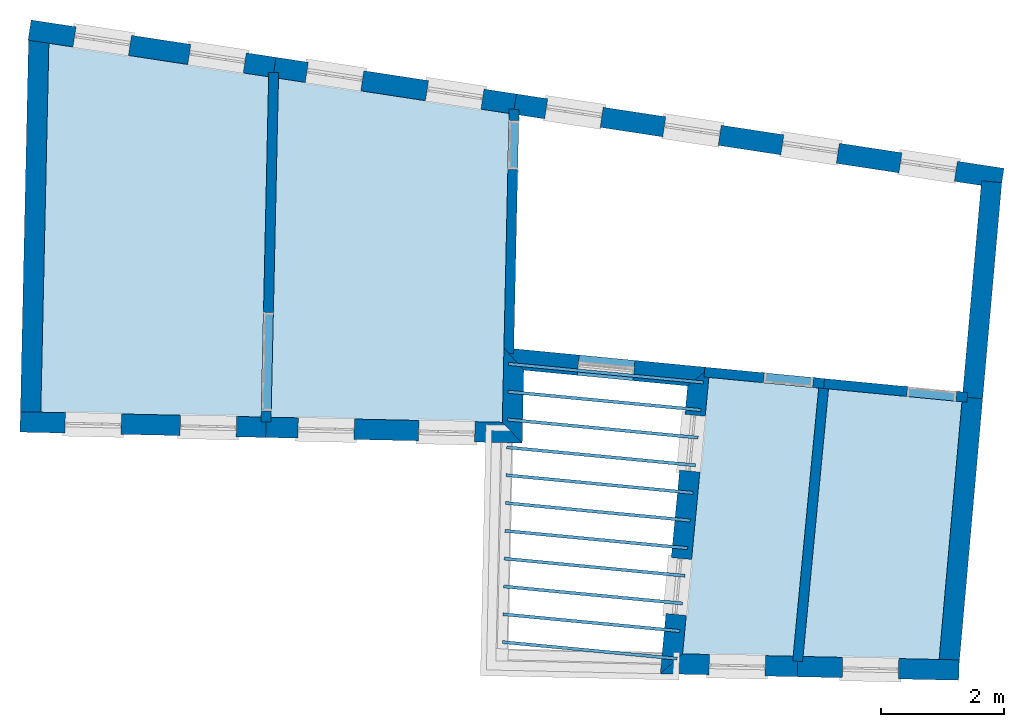
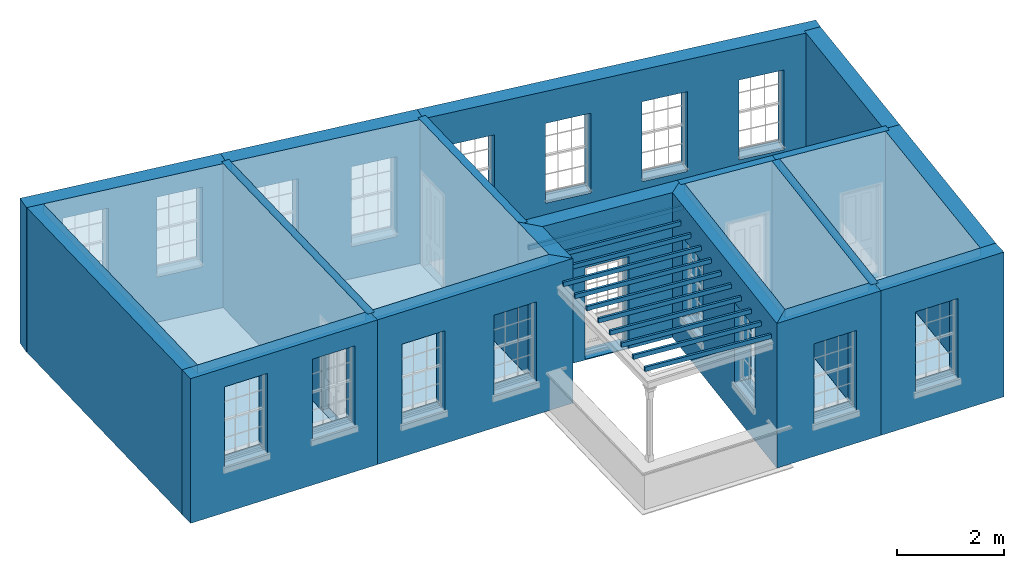
# One storey, part 1 of 12: 19 slabs, 18 walls, 21 openings.
"""IFC2X3 building model written with IfcOpenShell, lengths in metres."""

from ifc_helpers import new_model, si_unit, frame, origin, place, context, subcontext, project, spatial, polyline, outline, extrude, material, layer, layer_set, layer_usage, element, save


model = new_model("IFC2X3")

# Units and contexts
model_context = context("Model", 3, world=origin())
body_context = subcontext(model_context, "Body", "Model", "MODEL_VIEW")
ifc_project = project(units=[si_unit("PLANEANGLEUNIT", "RADIAN"), si_unit("MASSUNIT", "GRAM", prefix="KILO"), si_unit("FORCEUNIT", "NEWTON", prefix="KILO"), si_unit("LENGTHUNIT", "METRE")], contexts=[model_context])

# Site, building, storey
site_placement = place(None, origin())
site = spatial("IfcSite", under=ifc_project, at=site_placement, CompositionType="ELEMENT")
building_placement = place(None, origin())
building = spatial("IfcBuilding", under=site, at=building_placement, Name="Building plot-18", CompositionType="ELEMENT")
storey_placement = place(None, frame((0.0, 0.0, 6.6)))
storey = spatial("IfcBuildingStorey", under=building, at=storey_placement, Name="Floor 1", CompositionType="ELEMENT", Elevation=6.6)

# Slabs
slab_1_placement = place(storey_placement, frame((0.0, 0.0, 3.1)))
element("IfcSlab", 1, at=slab_1_placement, inside=storey, Name="Slab", ObjectType="Slab", PredefinedType="FLOOR", context=body_context, shape_type="SweptSolid", body=[
    extrude(outline(polyline([(90.0665092699253, 26.2497874759224), (86.5022934800522, 26.793269433689), (86.3714411265754, 20.8107101060855), (89.9458341375318, 20.7325298972281), (90.0665092699253, 26.2497874759224)])), origin(), (0.0, 0.0, 1.0), 0.2),
])
slab_2_placement = place(storey_placement, frame((0.0, 0.0, 2.8)))
element("IfcSlab", 2, at=slab_2_placement, inside=storey, Name="Slab", ObjectType="Slab", PredefinedType="FLOOR", context=body_context, shape_type="SweptSolid", body=[
    extrude(outline(polyline([(96.6890640935905, 16.7886954747635), (96.6938006517783, 16.8384706193291), (93.8601903908581, 17.1081144345203), (93.8554538326703, 17.0583392899546), (96.6890640935905, 16.7886954747635)])), origin(), (0.0, 0.0, 1.0), 0.1),
])
slab_3_placement = place(storey_placement, frame((0.0, 0.0, 2.8)))
element("IfcSlab", 3, at=slab_3_placement, inside=storey, Name="Slab", ObjectType="Slab", PredefinedType="FLOOR", context=body_context, shape_type="SweptSolid", body=[
    extrude(outline(polyline([(96.7316931172806, 17.2366717758545), (96.7364296754684, 17.2864469204202), (93.8700568548032, 17.5592083914608), (93.8653202966154, 17.5094332468951), (96.7316931172806, 17.2366717758545)])), origin(), (0.0, 0.0, 1.0), 0.1),
])
slab_4_placement = place(storey_placement, frame((0.0, 0.0, 2.8)))
element("IfcSlab", 4, at=slab_4_placement, inside=storey, Name="Slab", ObjectType="Slab", PredefinedType="FLOOR", context=body_context, shape_type="SweptSolid", body=[
    extrude(outline(polyline([(96.7743221409708, 17.6846480769456), (96.7790586991586, 17.7344232215112), (93.8799233187482, 18.0103023484013), (93.8751867605604, 17.9605272038357), (96.7743221409708, 17.6846480769456)])), origin(), (0.0, 0.0, 1.0), 0.1),
])
slab_5_placement = place(storey_placement, frame((0.0, 0.0, 2.8)))
element("IfcSlab", 5, at=slab_5_placement, inside=storey, Name="Slab", ObjectType="Slab", PredefinedType="FLOOR", context=body_context, shape_type="SweptSolid", body=[
    extrude(outline(polyline([(96.8169511646609, 18.1326243780366), (96.8216877228487, 18.1823995226023), (93.8897897826932, 18.4613963053419), (93.8850532245054, 18.4116211607762), (96.8169511646609, 18.1326243780366)])), origin(), (0.0, 0.0, 1.0), 0.1),
])
slab_6_placement = place(storey_placement, frame((0.0, 0.0, 2.8)))
element("IfcSlab", 6, at=slab_6_placement, inside=storey, Name="Slab", ObjectType="Slab", PredefinedType="FLOOR", context=body_context, shape_type="SweptSolid", body=[
    extrude(outline(polyline([(96.8595801883511, 18.5806006791277), (96.8643167465389, 18.6303758236934), (93.8996562466383, 18.9124902622824), (93.8949196884505, 18.8627151177167), (96.8595801883511, 18.5806006791277)])), origin(), (0.0, 0.0, 1.0), 0.1),
])
slab_7_placement = place(storey_placement, frame((0.0, 0.0, 2.8)))
element("IfcSlab", 7, at=slab_7_placement, inside=storey, Name="Slab", ObjectType="Slab", PredefinedType="FLOOR", context=body_context, shape_type="SweptSolid", body=[
    extrude(outline(polyline([(96.9022092120412, 19.0285769802188), (96.906945770229, 19.0783521247844), (93.9095227105833, 19.3635842192229), (93.9047861523955, 19.3138090746573), (96.9022092120412, 19.0285769802188)])), origin(), (0.0, 0.0, 1.0), 0.1),
])
slab_8_placement = place(storey_placement, frame((0.0, 0.0, 2.8)))
element("IfcSlab", 8, at=slab_8_placement, inside=storey, Name="Slab", ObjectType="Slab", PredefinedType="FLOOR", context=body_context, shape_type="SweptSolid", body=[
    extrude(outline(polyline([(96.9448382357314, 19.4765532813098), (96.9495747939192, 19.5263284258755), (93.9193891745284, 19.8146781761635), (93.9146526163406, 19.7649030315978), (96.9448382357314, 19.4765532813098)])), origin(), (0.0, 0.0, 1.0), 0.1),
])
slab_9_placement = place(storey_placement, frame((0.0, 0.0, 2.8)))
element("IfcSlab", 9, at=slab_9_placement, inside=storey, Name="Slab", ObjectType="Slab", PredefinedType="FLOOR", context=body_context, shape_type="SweptSolid", body=[
    extrude(outline(polyline([(96.9874672594215, 19.9245295824009), (96.9922038176093, 19.9743047269665), (93.9292556384734, 20.265772133104), (93.9245190802856, 20.2159969885383), (96.9874672594215, 19.9245295824009)])), origin(), (0.0, 0.0, 1.0), 0.1),
])
slab_10_placement = place(storey_placement, frame((0.0, 0.0, 2.8)))
element("IfcSlab", 10, at=slab_10_placement, inside=storey, Name="Slab", ObjectType="Slab", PredefinedType="FLOOR", context=body_context, shape_type="SweptSolid", body=[
    extrude(outline(polyline([(97.0300962831116, 20.3725058834919), (97.0348328412994, 20.4222810280576), (93.9391221024184, 20.7168660900445), (93.9343855442306, 20.6670909454789), (97.0300962831116, 20.3725058834919)])), origin(), (0.0, 0.0, 1.0), 0.1),
])
slab_11_placement = place(storey_placement, frame((0.0, 0.0, 2.8)))
element("IfcSlab", 11, at=slab_11_placement, inside=storey, Name="Slab", ObjectType="Slab", PredefinedType="FLOOR", context=body_context, shape_type="SweptSolid", body=[
    extrude(outline(polyline([(97.0727253068018, 20.820482184583), (97.0774618649896, 20.8702573291487), (93.9489885663635, 21.1679600469851), (93.9442520081757, 21.1181849024194), (97.0727253068018, 20.820482184583)])), origin(), (0.0, 0.0, 1.0), 0.1),
])
slab_12_placement = place(storey_placement, frame((0.0, 0.0, 2.8)))
element("IfcSlab", 12, at=slab_12_placement, inside=storey, Name="Slab", ObjectType="Slab", PredefinedType="FLOOR", context=body_context, shape_type="SweptSolid", body=[
    extrude(outline(polyline([(97.1153543304919, 21.268458485674), (97.1200908886797, 21.3182336302397), (93.9588550303085, 21.6190540039256), (93.9541184721207, 21.5692788593599), (97.1153543304919, 21.268458485674)])), origin(), (0.0, 0.0, 1.0), 0.1),
])
slab_13_placement = place(storey_placement, frame((0.0, 0.0, 3.1)))
element("IfcSlab", 13, at=slab_13_placement, inside=storey, Name="Slab", ObjectType="Slab", PredefinedType="FLOOR", context=body_context, shape_type="SweptSolid", body=[
    extrude(outline(polyline([(93.9652937343678, 25.6552895166051), (90.2260155594004, 26.2254654944291), (90.1057958794453, 20.7290311654569), (93.8557511466322, 20.6470110056427), (93.9652937343678, 25.6552895166051)])), origin(), (0.0, 0.0, 1.0), 0.2),
])
slab_14_placement = place(storey_placement, frame((0.0, 0.0, 3.1)))
element("IfcSlab", 14, at=slab_14_placement, inside=storey, Name="Slab", ObjectType="Slab", PredefinedType="FLOOR", context=body_context, shape_type="SweptSolid", body=[
    extrude(outline(polyline([(96.7792255874086, 16.8916819408247), (98.5722410978442, 16.8524645613532), (98.9862368117979, 21.2030279228927), (97.2057969153529, 21.3743988576596), (96.7792255874086, 16.8916819408247)])), origin(), (0.0, 0.0, 1.0), 0.2),
])
slab_15_placement = place(storey_placement, frame((0.0, 0.0, 3.1)))
element("IfcSlab", 15, at=slab_15_placement, inside=storey, Name="Slab", ObjectType="Slab", PredefinedType="FLOOR", context=body_context, shape_type="SweptSolid", body=[
    extrude(outline(polyline([(98.7326300603119, 16.8489564852837), (100.939309623709, 16.8006913200882), (101.309526101752, 20.9794066379798), (99.1455008594679, 21.1876984367481), (98.7326300603119, 16.8489564852837)])), origin(), (0.0, 0.0, 1.0), 0.2),
])
slab_16_placement = place(storey_placement, origin())
element("IfcSlab", 16, at=slab_16_placement, inside=storey, Name="Slab", ObjectType="Slab", PredefinedType="FLOOR", context=body_context, shape_type="SweptSolid", body=[
    extrude(outline(polyline([(90.0665092699253, 26.2497874759224), (86.5022934800522, 26.793269433689), (86.3714411265754, 20.8107101060855), (89.9458341375318, 20.7325298972281), (90.0665092699253, 26.2497874759224)])), origin(), (0.0, 0.0, 1.0), 0.02),
])
slab_17_placement = place(storey_placement, origin())
element("IfcSlab", 17, at=slab_17_placement, inside=storey, Name="Slab", ObjectType="Slab", PredefinedType="FLOOR", context=body_context, shape_type="SweptSolid", body=[
    extrude(outline(polyline([(93.9652937343678, 25.6552895166051), (90.2260155594004, 26.2254654944291), (90.1057958794453, 20.7290311654569), (93.8557511466322, 20.6470110056427), (93.9652937343678, 25.6552895166051)])), origin(), (0.0, 0.0, 1.0), 0.02),
])
slab_18_placement = place(storey_placement, origin())
element("IfcSlab", 18, at=slab_18_placement, inside=storey, Name="Slab", ObjectType="Slab", PredefinedType="FLOOR", context=body_context, shape_type="SweptSolid", body=[
    extrude(outline(polyline([(96.7792255874086, 16.8916819408247), (98.5722410978442, 16.8524645613532), (98.9862368117979, 21.2030279228927), (97.2057969153529, 21.3743988576596), (96.7792255874086, 16.8916819408247)])), origin(), (0.0, 0.0, 1.0), 0.02),
])
slab_19_placement = place(storey_placement, origin())
element("IfcSlab", 19, at=slab_19_placement, inside=storey, Name="Slab", ObjectType="Slab", PredefinedType="FLOOR", context=body_context, shape_type="SweptSolid", body=[
    extrude(outline(polyline([(98.7326300603119, 16.8489564852837), (100.939309623709, 16.8006913200882), (101.309526101752, 20.9794066379798), (99.1455008594679, 21.1876984367481), (98.7326300603119, 16.8489564852837)])), origin(), (0.0, 0.0, 1.0), 0.02),
])

# Wall, openings
ifc_material_1 = material(Name="Masonry")
ifc_layer_1 = layer(ifc_material_1, 0.33, ventilated=False)
ifc_layer_set_1 = layer_set([ifc_layer_1], Name="My Wall")
ifc_layer_usage_1 = layer_usage(ifc_layer_set_1, "AXIS2", "NEGATIVE", 0.08)
wall_1_placement = place(storey_placement, origin())
wall_1 = element("IfcWallStandardCase", 20, at=wall_1_placement, inside=storey, material=ifc_layer_usage_1, Name="exterior", context=body_context, shape_type="SweptSolid", body=[
    extrude(outline(polyline([(86.0415200338789, 20.8179262403648), (86.0343038995997, 20.4880051476683), (90.0185988742094, 20.4008594386457), (90.0258150084886, 20.7307805313422), (86.0415200338789, 20.8179262403648)])), origin(), (0.0, 0.0, 1.0), 3.3),
])
opening_1_placement = place(storey_placement, frame((0.0, 0.0, 1.05)))
element("IfcOpeningElement", 21, at=opening_1_placement, cuts=wall_1, Name="Opening", ObjectType="Opening", context=body_context, shape_type="SweptSolid", body=[
    extrude(outline(polyline([(86.7629416059906, 20.4720681625935), (87.6727240131234, 20.4521691256419), (87.6799401474025, 20.7820902183384), (86.7701577402697, 20.80198925529), (86.7629416059906, 20.4720681625935)])), origin(), (0.0, 0.0, 1.0), 1.82),
])
opening_2_placement = place(storey_placement, frame((0.0, 0.0, 1.05)))
element("IfcOpeningElement", 22, at=opening_2_placement, cuts=wall_1, Name="Opening", ObjectType="Opening", context=body_context, shape_type="SweptSolid", body=[
    extrude(outline(polyline([(88.6301189824255, 20.4312286922788), (89.5399013895583, 20.4113296553272), (89.5471175238375, 20.7412507480237), (88.6373351167047, 20.7611497849754), (88.6301189824255, 20.4312286922788)])), origin(), (0.0, 0.0, 1.0), 1.82),
])

wall_2_placement = place(storey_placement, origin())
wall_2 = element("IfcWallStandardCase", 23, at=wall_2_placement, inside=storey, material=ifc_layer_usage_1, Name="exterior", context=body_context, shape_type="SweptSolid", body=[
    extrude(outline(polyline([(90.0258150084886, 20.7307805313422), (90.0185988742094, 20.4008594386457), (94.1784561050496, 20.309873778667), (93.8557511466322, 20.6470110056427), (90.0258150084886, 20.7307805313422)])), origin(), (0.0, 0.0, 1.0), 3.3),
])
opening_3_placement = place(storey_placement, frame((0.0, 0.0, 0.75)))
element("IfcOpeningElement", 24, at=opening_3_placement, cuts=wall_2, Name="Opening", ObjectType="Opening", context=body_context, shape_type="SweptSolid", body=[
    extrude(outline(polyline([(90.5411869229181, 20.3894292342252), (91.4509693300509, 20.3695301972735), (91.4581854643301, 20.6994512899701), (90.5484030571972, 20.7193503269217), (90.5411869229181, 20.3894292342252)])), origin(), (0.0, 0.0, 1.0), 1.82),
])
opening_4_placement = place(storey_placement, frame((0.0, 0.0, 0.75)))
element("IfcOpeningElement", 25, at=opening_4_placement, cuts=wall_2, Name="Opening", ObjectType="Opening", context=body_context, shape_type="SweptSolid", body=[
    extrude(outline(polyline([(92.4961454274683, 20.3466697884325), (93.4059278346011, 20.3267707514808), (93.4131439688803, 20.6566918441774), (92.5033615617474, 20.676590881129), (92.4961454274683, 20.3466697884325)])), origin(), (0.0, 0.0, 1.0), 1.82),
])

# Wall
wall_3_placement = place(storey_placement, origin())
element("IfcWallStandardCase", 26, at=wall_3_placement, inside=storey, material=ifc_layer_usage_1, Name="exterior", context=body_context, shape_type="SweptSolid", body=[
    extrude(outline(polyline([(93.8557511466322, 20.6470110056427), (94.1784561050496, 20.309873778667), (94.2043231076959, 21.492511108805), (93.8821736056846, 21.8550437590575), (93.8557511466322, 20.6470110056427)])), origin(), (0.0, 0.0, 1.0), 3.3),
])

# Wall, opening
wall_4_placement = place(storey_placement, origin())
wall_4 = element("IfcWallStandardCase", 27, at=wall_4_placement, inside=storey, material=ifc_layer_usage_1, Name="exterior", context=body_context, shape_type="SweptSolid", body=[
    extrude(outline(polyline([(93.8821736056846, 21.8550437590575), (94.2043231076959, 21.492511108805), (96.8612105097509, 21.2367803320634), (97.2209539104425, 21.533679413678), (93.8821736056846, 21.8550437590575)])), origin(), (0.0, 0.0, 1.0), 3.3),
])
opening_5_placement = place(storey_placement, frame((0.0, 0.0, 0.0199999999999996)))
element("IfcOpeningElement", 28, at=opening_5_placement, cuts=wall_4, Name="Opening", ObjectType="Opening", context=body_context, shape_type="SweptSolid", body=[
    extrude(outline(polyline([(95.0701477438461, 21.4091737394635), (95.9759614837646, 21.3219873381452), (96.0075785303965, 21.65046924383), (95.101764790478, 21.7376556451482), (95.0701477438461, 21.4091737394635)])), origin(), (0.0, 0.0, 1.0), 2.08),
])

# Wall, openings
wall_5_placement = place(storey_placement, origin())
wall_5 = element("IfcWallStandardCase", 29, at=wall_5_placement, inside=storey, material=ifc_layer_usage_1, Name="exterior", context=body_context, shape_type="SweptSolid", body=[
    extrude(outline(polyline([(97.2209539104425, 21.533679413678), (96.8612105097509, 21.2367803320634), (96.4170785766712, 16.5695240039888), (96.7792255874086, 16.8916819408247), (97.2209539104425, 21.533679413678)])), origin(), (0.0, 0.0, 1.0), 3.3),
])
opening_6_placement = place(storey_placement, frame((0.0, 0.0, 0.75)))
element("IfcOpeningElement", 30, at=opening_6_placement, cuts=wall_5, Name="Opening", ObjectType="Opening", context=body_context, shape_type="SweptSolid", body=[
    extrude(outline(polyline([(96.8173925916487, 20.776310277304), (96.7311872326308, 19.8704026462087), (97.0597031867643, 19.8391413621693), (97.1459085457821, 20.7450489932646), (96.8173925916487, 20.776310277304)])), origin(), (0.0, 0.0, 1.0), 1.82),
])
opening_7_placement = place(storey_placement, frame((0.0, 0.0, 0.75)))
element("IfcOpeningElement", 31, at=opening_7_placement, cuts=wall_5, Name="Opening", ObjectType="Opening", context=body_context, shape_type="SweptSolid", body=[
    extrude(outline(polyline([(96.5962370834595, 18.4522498614566), (96.5100317244417, 17.5463422303613), (96.8385476785751, 17.5150809463219), (96.924753037593, 18.4209885774172), (96.5962370834595, 18.4522498614566)])), origin(), (0.0, 0.0, 1.0), 1.82),
])

# Wall, opening
wall_6_placement = place(storey_placement, origin())
wall_6 = element("IfcWallStandardCase", 32, at=wall_6_placement, inside=storey, material=ifc_layer_usage_1, Name="exterior", context=body_context, shape_type="SweptSolid", body=[
    extrude(outline(polyline([(96.7792255874086, 16.8916819408247), (96.4170785766712, 16.5695240039888), (98.6393700771944, 16.5209173697657), (98.6465862114736, 16.8508384624622), (96.7792255874086, 16.8916819408247)])), origin(), (0.0, 0.0, 1.0), 3.3),
])
opening_8_placement = place(storey_placement, frame((0.0, 0.0, 0.75)))
element("IfcOpeningElement", 33, at=opening_8_placement, cuts=wall_6, Name="Opening", ObjectType="Opening", context=body_context, shape_type="SweptSolid", body=[
    extrude(outline(polyline([(97.2077766371763, 16.5522296160119), (98.1175590443092, 16.5323305790603), (98.1247751785883, 16.8622516717568), (97.2149927714555, 16.8821507087084), (97.2077766371763, 16.5522296160119)])), origin(), (0.0, 0.0, 1.0), 1.82),
])

wall_7_placement = place(storey_placement, origin())
wall_7 = element("IfcWallStandardCase", 34, at=wall_7_placement, inside=storey, material=ifc_layer_usage_1, Name="exterior", context=body_context, shape_type="SweptSolid", body=[
    extrude(outline(polyline([(98.6465862114736, 16.8508384624622), (98.6393700771944, 16.5209173697657), (101.256865456868, 16.463666716343), (101.264081591148, 16.7935878090395), (98.6465862114736, 16.8508384624622)])), origin(), (0.0, 0.0, 1.0), 3.3),
])
opening_9_placement = place(storey_placement, frame((0.0, 0.0, 0.75)))
element("IfcOpeningElement", 35, at=opening_9_placement, cuts=wall_7, Name="Opening", ObjectType="Opening", context=body_context, shape_type="SweptSolid", body=[
    extrude(outline(polyline([(99.3682564525951, 16.5049749457268), (100.278038859728, 16.4850759087752), (100.285254994007, 16.8149970014717), (99.3754725868743, 16.8348960384233), (99.3682564525951, 16.5049749457268)])), origin(), (0.0, 0.0, 1.0), 1.82),
])

# Wall, openings
wall_8_placement = place(storey_placement, origin())
wall_8 = element("IfcWallStandardCase", 36, at=wall_8_placement, inside=storey, material=ifc_layer_usage_1, Name="exterior", context=body_context, shape_type="SweptSolid", body=[
    extrude(outline(polyline([(101.941775393575, 24.4390124661107), (101.991519769301, 24.7652416755381), (94.0844961381432, 25.9709275645287), (94.0347517624171, 25.6446983551013), (101.941775393575, 24.4390124661107)])), origin(), (0.0, 0.0, 1.0), 3.3),
])
opening_10_placement = place(storey_placement, frame((0.0, 0.0, 0.75)))
element("IfcOpeningElement", 37, at=opening_10_placement, cuts=wall_8, Name="Opening", ObjectType="Opening", context=body_context, shape_type="SweptSolid", body=[
    extrude(outline(polyline([(101.236692272156, 24.880339960858), (100.337090512825, 25.017513845436), (100.287346137099, 24.6912846360086), (101.186947896429, 24.5541107514306), (101.236692272156, 24.880339960858)])), origin(), (0.0, 0.0, 1.0), 1.82),
])
opening_11_placement = place(storey_placement, frame((0.0, 0.0, 0.75)))
element("IfcOpeningElement", 38, at=opening_11_placement, cuts=wall_8, Name="Opening", ObjectType="Opening", context=body_context, shape_type="SweptSolid", body=[
    extrude(outline(polyline([(99.3217221994849, 25.1723401498242), (98.4221204401548, 25.3095140344022), (98.3723760644287, 24.9832848249748), (99.2719778237588, 24.8461109403968), (99.3217221994849, 25.1723401498242)])), origin(), (0.0, 0.0, 1.0), 1.82),
])
opening_12_placement = place(storey_placement, frame((0.0, 0.0, 0.75)))
element("IfcOpeningElement", 39, at=opening_12_placement, cuts=wall_8, Name="Opening", ObjectType="Opening", context=body_context, shape_type="SweptSolid", body=[
    extrude(outline(polyline([(97.4067521268142, 25.4643403387904), (96.5071503674841, 25.6015142233684), (96.4574059917581, 25.275285013941), (97.3570077510882, 25.138111129363), (97.4067521268142, 25.4643403387904)])), origin(), (0.0, 0.0, 1.0), 1.82),
])
opening_13_placement = place(storey_placement, frame((0.0, 0.0, 0.75)))
element("IfcOpeningElement", 40, at=opening_13_placement, cuts=wall_8, Name="Opening", ObjectType="Opening", context=body_context, shape_type="SweptSolid", body=[
    extrude(outline(polyline([(95.4917820541436, 25.7563405277566), (94.5921802948135, 25.8935144123346), (94.5424359190874, 25.5672852029072), (95.4420376784175, 25.4301113183292), (95.4917820541436, 25.7563405277566)])), origin(), (0.0, 0.0, 1.0), 1.82),
])

wall_9_placement = place(storey_placement, origin())
wall_9 = element("IfcWallStandardCase", 41, at=wall_9_placement, inside=storey, material=ifc_layer_usage_1, Name="exterior", context=body_context, shape_type="SweptSolid", body=[
    extrude(outline(polyline([(94.0347517624171, 25.6446983551013), (94.0844961381432, 25.9709275645287), (90.1857116737007, 26.5654255238456), (90.1359672979746, 26.2391963144182), (94.0347517624171, 25.6446983551013)])), origin(), (0.0, 0.0, 1.0), 3.3),
])
opening_14_placement = place(storey_placement, frame((0.0, 0.0, 0.75)))
element("IfcOpeningElement", 42, at=opening_14_placement, cuts=wall_9, Name="Opening", ObjectType="Opening", context=body_context, shape_type="SweptSolid", body=[
    extrude(outline(polyline([(93.5596009016976, 26.050965112069), (92.6599991423675, 26.1881389966469), (92.6102547666415, 25.8619097872195), (93.5098565259716, 25.7247359026416), (93.5596009016976, 26.050965112069)])), origin(), (0.0, 0.0, 1.0), 1.82),
])
opening_15_placement = place(storey_placement, frame((0.0, 0.0, 0.75)))
element("IfcOpeningElement", 43, at=opening_15_placement, cuts=wall_9, Name="Opening", ObjectType="Opening", context=body_context, shape_type="SweptSolid", body=[
    extrude(outline(polyline([(91.6102086694764, 26.3482140917274), (90.7106069101463, 26.4853879763053), (90.6608625344202, 26.1591587668779), (91.5604642937503, 26.0219848823), (91.6102086694764, 26.3482140917274)])), origin(), (0.0, 0.0, 1.0), 1.82),
])

wall_10_placement = place(storey_placement, origin())
wall_10 = element("IfcWallStandardCase", 44, at=wall_10_placement, inside=storey, material=ifc_layer_usage_1, Name="exterior", context=body_context, shape_type="SweptSolid", body=[
    extrude(outline(polyline([(90.1359672979746, 26.2391963144182), (90.1857116737007, 26.5654255238456), (86.2148462538772, 27.1709145962313), (86.1651018781511, 26.8446853868039), (90.1359672979746, 26.2391963144182)])), origin(), (0.0, 0.0, 1.0), 3.3),
])
opening_16_placement = place(storey_placement, frame((0.0, 0.0, 1.05)))
element("IfcOpeningElement", 45, at=opening_16_placement, cuts=wall_10, Name="Opening", ObjectType="Opening", context=body_context, shape_type="SweptSolid", body=[
    extrude(outline(polyline([(89.7045820335287, 26.6387895663716), (88.8049802741986, 26.7759634509495), (88.7552358984725, 26.4497342415221), (89.6548376578026, 26.3125603569442), (89.7045820335287, 26.6387895663716)])), origin(), (0.0, 0.0, 1.0), 1.82),
])
opening_17_placement = place(storey_placement, frame((0.0, 0.0, 1.05)))
element("IfcOpeningElement", 46, at=opening_17_placement, cuts=wall_10, Name="Opening", ObjectType="Opening", context=body_context, shape_type="SweptSolid", body=[
    extrude(outline(polyline([(87.8427209938546, 26.9226915360016), (86.9431192345245, 27.0598654205795), (86.8933748587984, 26.7336362111521), (87.7929766181285, 26.5964623265742), (87.8427209938546, 26.9226915360016)])), origin(), (0.0, 0.0, 1.0), 1.82),
])

# Walls
wall_11_placement = place(storey_placement, origin())
element("IfcWallStandardCase", 47, at=wall_11_placement, inside=storey, material=ifc_layer_usage_1, Name="party", context=body_context, shape_type="SweptSolid", body=[
    extrude(outline(polyline([(86.5042853321834, 26.8843367567443), (86.1743642394869, 26.8915528910235), (86.039770667993, 20.7379453694081), (86.3696917606895, 20.7307292351289), (86.5042853321834, 26.8843367567443)])), origin(), (0.0, 0.0, 1.0), 3.3),
])
wall_12_placement = place(storey_placement, origin())
element("IfcWallStandardCase", 48, at=wall_12_placement, inside=storey, material=ifc_layer_usage_1, Name="party", context=body_context, shape_type="SweptSolid", body=[
    extrude(outline(polyline([(100.932704135606, 16.7261337140522), (101.26141659076, 16.6970111828008), (101.645245171745, 21.0293693190009), (101.316532716591, 21.0584918502523), (100.932704135606, 16.7261337140522)])), origin(), (0.0, 0.0, 1.0), 3.3),
])
wall_13_placement = place(storey_placement, origin())
element("IfcWallStandardCase", 49, at=wall_13_placement, inside=storey, material=ifc_layer_usage_1, Name="party", context=body_context, shape_type="SweptSolid", body=[
    extrude(outline(polyline([(101.316532716591, 21.0584918502523), (101.645245171745, 21.0293693190009), (101.955715882938, 24.5337209445133), (101.627003427784, 24.5628434757647), (101.316532716591, 21.0584918502523)])), origin(), (0.0, 0.0, 1.0), 3.3),
])

# Wall, opening
ifc_material_2 = material(Name="Masonry")
ifc_layer_2 = layer(ifc_material_2, 0.16, ventilated=False)
ifc_layer_set_2 = layer_set([ifc_layer_2], Name="My Wall")
ifc_layer_usage_2 = layer_usage(ifc_layer_set_2, "AXIS2", "NEGATIVE", 0.08)
wall_14_placement = place(storey_placement, origin())
wall_14 = element("IfcWallStandardCase", 50, at=wall_14_placement, inside=storey, material=ifc_layer_usage_2, Name="interior", context=body_context, shape_type="SweptSolid", body=[
    extrude(outline(polyline([(99.0811120717551, 21.3546354349653), (99.0657825946003, 21.1953714806939), (101.38855584593, 20.9717998655405), (101.403885323084, 21.1310638198119), (99.0811120717551, 21.3546354349653)])), origin(), (0.0, 0.0, 1.0), 3.3),
])
opening_18_placement = place(storey_placement, frame((0.0, 0.0, 0.0199999999999996)))
element("IfcOpeningElement", 51, at=opening_18_placement, cuts=wall_14, Name="Opening", ObjectType="Opening", context=body_context, shape_type="SweptSolid", body=[
    extrude(outline(polyline([(100.413064126017, 21.065692913114), (101.209383897374, 20.9890455273397), (101.224713374529, 21.1483094816111), (100.428393603172, 21.2249568673854), (100.413064126017, 21.065692913114)])), origin(), (0.0, 0.0, 1.0), 2.1),
])

wall_15_placement = place(storey_placement, origin())
wall_15 = element("IfcWallStandardCase", 52, at=wall_15_placement, inside=storey, material=ifc_layer_usage_2, Name="interior", context=body_context, shape_type="SweptSolid", body=[
    extrude(outline(polyline([(93.8802895837003, 21.7689064218516), (94.0402513256137, 21.7654076900798), (94.1267918759741, 25.7220348581675), (93.9668301340607, 25.7255335899393), (93.8802895837003, 21.7689064218516)])), origin(), (0.0, 0.0, 1.0), 3.3),
])
opening_19_placement = place(storey_placement, frame((0.0, 0.0, 0.0199999999999996)))
element("IfcOpeningElement", 53, at=opening_19_placement, cuts=wall_15, Name="Opening", ObjectType="Opening", context=body_context, shape_type="SweptSolid", body=[
    extrude(outline(polyline([(94.1053621438724, 24.7422691889476), (94.122855802731, 25.5420778985149), (93.9628940608175, 25.5455766302866), (93.9454004019589, 24.7457679207193), (94.1053621438724, 24.7422691889476)])), origin(), (0.0, 0.0, 1.0), 2.1),
])

# Wall
wall_16_placement = place(storey_placement, origin())
element("IfcWallStandardCase", 54, at=wall_16_placement, inside=storey, material=ifc_layer_usage_2, Name="interior", context=body_context, shape_type="SweptSolid", body=[
    extrude(outline(polyline([(98.5651966142826, 16.778436084606), (98.7244770768928, 16.763279098405), (99.1530875644828, 21.2674249647291), (98.9938071018726, 21.2825819509301), (98.5651966142826, 16.778436084606)])), origin(), (0.0, 0.0, 1.0), 3.3),
])

# Wall, opening
wall_17_placement = place(storey_placement, origin())
wall_17 = element("IfcWallStandardCase", 55, at=wall_17_placement, inside=storey, material=ifc_layer_usage_2, Name="interior", context=body_context, shape_type="SweptSolid", body=[
    extrude(outline(polyline([(99.0657825946003, 21.1953714806939), (99.0811120717551, 21.3546354349653), (97.1414081276401, 21.5413358558768), (97.1260786504853, 21.3820719016054), (99.0657825946003, 21.1953714806939)])), origin(), (0.0, 0.0, 1.0), 3.3),
])
opening_20_placement = place(storey_placement, frame((0.0, 0.0, 0.0199999999999996)))
element("IfcOpeningElement", 56, at=opening_20_placement, cuts=wall_17, Name="Opening", ObjectType="Opening", context=body_context, shape_type="SweptSolid", body=[
    extrude(outline(polyline([(98.9019401231998, 21.3718810967645), (98.1056203518429, 21.4485284825388), (98.090290874688, 21.2892645282674), (98.886610646045, 21.2126171424931), (98.9019401231998, 21.3718810967645)])), origin(), (0.0, 0.0, 1.0), 2.1),
])

wall_18_placement = place(storey_placement, origin())
wall_18 = element("IfcWallStandardCase", 57, at=wall_18_placement, inside=storey, material=ifc_layer_usage_2, Name="interior", context=body_context, shape_type="SweptSolid", body=[
    extrude(outline(polyline([(89.944084771646, 20.6525490262714), (90.1040465135594, 20.6490502944996), (90.2280074115316, 26.3165328174844), (90.0680456696182, 26.3200315492562), (89.944084771646, 20.6525490262714)])), origin(), (0.0, 0.0, 1.0), 3.3),
])
opening_21_placement = place(storey_placement, frame((0.0, 0.0, 0.0199999999999996)))
element("IfcOpeningElement", 58, at=opening_21_placement, cuts=wall_18, Name="Opening", ObjectType="Opening", context=body_context, shape_type="SweptSolid", body=[
    extrude(outline(polyline([(90.1079825868026, 20.8290072541523), (90.1429699045197, 22.4286246732869), (89.9830081626063, 22.4321234050586), (89.9480208448891, 20.832505985924), (90.1079825868026, 20.8290072541523)])), origin(), (0.0, 0.0, 1.0), 2.1),
])

save(model, "model.ifc")
